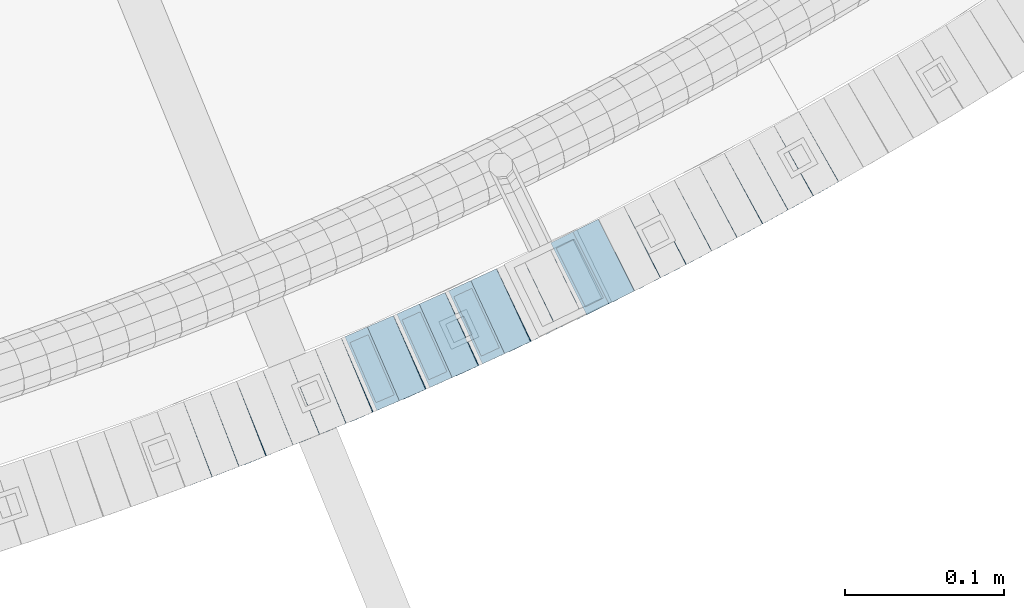
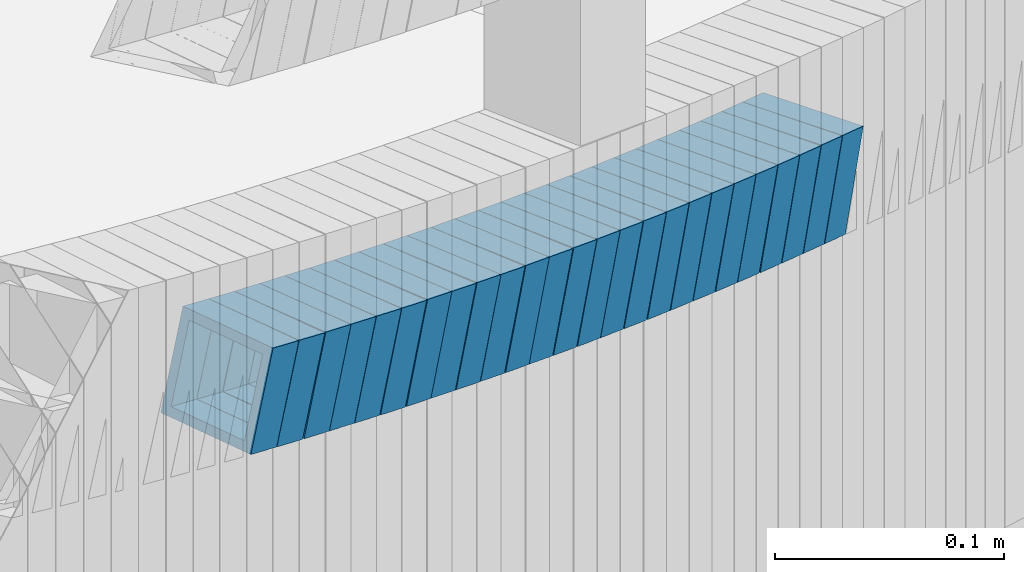
# One storey, part 763 of 975: 25 beams.
"""IFC2X3 building model written with IfcOpenShell, lengths in millimetres."""

from ifc_helpers import new_model, si_unit, frame, origin_with_axes, place, context, subcontext, project, spatial, faceted_brep, material, type_object, element, save


model = new_model("IFC2X3")

# Units and contexts
model_context = context("Model", 3, precision=1e-05, world=origin_with_axes())
body_context = subcontext(model_context, "Body", "Model", "MODEL_VIEW")
ifc_project = project(units=[si_unit("LENGTHUNIT", "METRE", prefix="MILLI"), si_unit("AREAUNIT", "SQUARE_METRE"), si_unit("VOLUMEUNIT", "CUBIC_METRE"), si_unit("MASSUNIT", "GRAM", prefix="KILO"), si_unit("TIMEUNIT", "SECOND"), si_unit("PLANEANGLEUNIT", "RADIAN"), si_unit("SOLIDANGLEUNIT", "STERADIAN"), si_unit("THERMODYNAMICTEMPERATUREUNIT", "DEGREE_CELSIUS"), si_unit("LUMINOUSINTENSITYUNIT", "LUMEN")], contexts=[model_context])

# Site, building, storey
site_placement = place(None, origin_with_axes())
site = spatial("IfcSite", under=ifc_project, at=site_placement, CompositionType="ELEMENT")
building_placement = place(site_placement, origin_with_axes())
building = spatial("IfcBuilding", under=site, at=building_placement, Name="Undefined", CompositionType="ELEMENT")
storey_placement = place(building_placement, origin_with_axes())
storey = spatial("IfcBuildingStorey", under=building, at=storey_placement, Name="Undefined", CompositionType="ELEMENT", Elevation=0.0)

# Beams
ifc_material = material()
beam_type = type_object("IfcBeamType", Name="HSS2X2X.188_TUBES", PredefinedType="NOTDEFINED")
beam_1_placement = place(storey_placement, frame((35750.552446329, 718.695826427397, 2958.19941195074), z_axis=(-0.357854758021058, 0.933777260465091, -4.67780409962871e-11), x_axis=(0.889683418026638, 0.340956519010209, -0.303664400009089)))
element("IfcBeam", 1, at=beam_1_placement, inside=storey, type_object=beam_type, material=ifc_material, Name="WALL", ObjectType="HSS2X2X.188_TUBES", context=body_context, shape_type="Brep", body=[
    faceted_brep([(0.0, 20.6374999999753, -20.6375000000298), (0.0, -20.6375000000153, -20.6375000000153), (18.767258723612, -20.6375000000025, -20.6374999999862), (18.7672587236229, 20.6374999999953, -20.637499999968), (0.0, -20.6374999999825, 20.6375000000335), (18.767258723612, -20.6375000000135, 20.6375000000153), (0.0, 20.6375000000116, 20.6375000000189), (18.7672587236266, 20.6374999999844, 20.6375000000371), (0.0, 25.3999999999724, -25.4000000000342), (0.0, 25.400000000016, 25.4000000000196), (18.7672587236302, 25.3999999999814, 25.4000000000342), (18.7672587236229, 25.399999999996, -25.3999999999687), (0.0, -25.399999999976, 25.4000000000378), (18.7672587236157, -25.4000000000142, 25.400000000016), (0.0, -25.400000000016, -25.4000000000196), (18.767258723612, -25.4000000000015, -25.3999999999905)], [[[0, 1, 2, 3]], [[1, 4, 5, 2]], [[4, 6, 7, 5]], [[6, 0, 3, 7]], [[8, 9, 10, 11]], [[9, 12, 13, 10]], [[12, 14, 15, 13]], [[14, 8, 11, 15]], [[13, 15, 11, 10], [5, 7, 3, 2]], [[14, 12, 9, 8], [6, 4, 1, 0]]]),
])
beam_2_placement = place(storey_placement, frame((35767.2894822871, 725.066744083415, 2952.53419018205), z_axis=(-0.362715533424744, 0.931899909760916, -1.4543775250786e-10), x_axis=(0.886618739868702, 0.345091125948895, -0.307927466954411)))
element("IfcBeam", 2, at=beam_2_placement, inside=storey, type_object=beam_type, material=ifc_material, Name="WALL", ObjectType="HSS2X2X.188_TUBES", context=body_context, shape_type="Brep", body=[
    faceted_brep([(0.0, 20.6374999999753, -20.6375000000298), (0.0, -20.6375000000153, -20.6375000000153), (18.8433011969464, -20.6374999999898, -20.6375000000226), (18.8433011969719, 20.6375000000007, -20.6374999999862), (0.0, -20.6374999999825, 20.6375000000335), (18.8433011969828, -20.6375000000044, 20.6375000000189), (0.0, 20.6375000000116, 20.6375000000189), (18.8433011970155, 20.6374999999862, 20.6375000000517), (0.0, 25.3999999999724, -25.4000000000342), (0.0, 25.400000000016, 25.4000000000196), (18.8433011970228, 25.3999999999833, 25.4000000000597), (18.8433011969719, 25.4000000000015, -25.3999999999869), (0.0, -25.399999999976, 25.4000000000378), (18.8433011969864, -25.4000000000051, 25.4000000000196), (0.0, -25.400000000016, -25.4000000000196), (18.8433011969391, -25.3999999999869, -25.4000000000269)], [[[0, 1, 2, 3]], [[1, 4, 5, 2]], [[4, 6, 7, 5]], [[6, 0, 3, 7]], [[8, 9, 10, 11]], [[9, 12, 13, 10]], [[12, 14, 15, 13]], [[14, 8, 11, 15]], [[13, 15, 11, 10], [5, 7, 3, 2]], [[14, 12, 9, 8], [6, 4, 1, 0]]]),
])
beam_3_placement = place(storey_placement, frame((35784.4255197932, 731.635710494934, 2946.69732250594), z_axis=(-0.374278314232696, 0.927316420373937, 2.4144355847966e-11), x_axis=(0.883603947282854, 0.356635328114164, -0.303406175097117)))
element("IfcBeam", 3, at=beam_3_placement, inside=storey, type_object=beam_type, material=ifc_material, Name="WALL", ObjectType="HSS2X2X.188_TUBES", context=body_context, shape_type="Brep", body=[
    faceted_brep([(0.0, 20.6374999999753, -20.6375000000298), (0.0, -20.6375000000153, -20.6375000000153), (18.7853666454903, -20.6375000000535, -20.6375000000326), (18.785366645363, 20.6374999999862, -20.6375000000044), (0.0, -20.6374999999825, 20.6375000000335), (18.785366645352, -20.6375000000007, 20.6374999999989), (0.0, 20.6375000000116, 20.6375000000189), (18.7853666453102, 20.6375000000025, 20.6374999999753), (0.0, 25.3999999999724, -25.4000000000342), (0.0, 25.400000000016, 25.4000000000196), (18.7853666452065, 25.4000000000451, 25.4000000000351), (18.7853666453739, 25.3999999999833, -25.400000000006), (0.0, -25.399999999976, 25.4000000000378), (18.7853666497213, -25.399999993424, 25.3999999995158), (0.0, -25.400000000016, -25.4000000000196), (18.7853666455194, -25.4000000000633, -25.4000000000406)], [[[0, 1, 2, 3]], [[1, 4, 5, 2]], [[4, 6, 7, 5]], [[6, 0, 3, 7]], [[8, 9, 10, 11]], [[9, 12, 13, 10]], [[12, 14, 15, 13]], [[14, 8, 11, 15]], [[13, 15, 11, 10], [5, 7, 3, 2]], [[14, 12, 9, 8], [6, 4, 1, 0]]]),
])
beam_4_placement = place(storey_placement, frame((35801.0473600464, 738.327037311758, 2941.00894090825), z_axis=(-0.376226421874497, 0.92652775429747, -7.30401552573312e-11), x_axis=(0.88242864795769, 0.358319511982818, -0.304838987985393)))
element("IfcBeam", 4, at=beam_4_placement, inside=storey, type_object=beam_type, material=ifc_material, Name="WALL", ObjectType="HSS2X2X.188_TUBES", context=body_context, shape_type="Brep", body=[
    faceted_brep([(0.0, 20.6374999999753, -20.6375000000298), (0.0, -20.6375000000153, -20.6375000000153), (18.6959888745805, -20.6374999999771, -20.6375000000407), (18.6959888746751, 20.637499999988, -20.6374999999716), (0.0, -20.6374999999825, 20.6375000000335), (18.6959888746969, -20.6375000000135, 20.6375000000371), (0.0, 20.6375000000116, 20.6375000000189), (18.6959888747988, 20.6374999999498, 20.6375000001062), (0.0, 25.3999999999724, -25.4000000000342), (0.0, 25.400000000016, 25.4000000000196), (18.695988874817, 25.3999999999414, 25.4000000001215), (18.6959888746678, 25.3999999999887, -25.399999999976), (0.0, -25.399999999976, 25.4000000000378), (18.6959888747042, -25.4000000000124, 25.4000000000378), (0.0, -25.400000000016, -25.4000000000196), (18.695988874555, -25.3999999999687, -25.4000000000597)], [[[0, 1, 2, 3]], [[1, 4, 5, 2]], [[4, 6, 7, 5]], [[6, 0, 3, 7]], [[8, 9, 10, 11]], [[9, 12, 13, 10]], [[12, 14, 15, 13]], [[14, 8, 11, 15]], [[13, 15, 11, 10], [5, 7, 3, 2]], [[14, 12, 9, 8], [6, 4, 1, 0]]]),
])
for number, where, z_axis, x_axis, name in (
    (5, (35817.5849439628, 744.998677276993, 2935.343717297), (-0.381031615465093, 0.924562008745796, -1.29251020553056e-10), (0.879290601000781, 0.362374308000324, -0.309083969000288), "WALL"),
    (6, (35834.3488784214, 751.86469113724, 2929.49937706686), (-0.385806130206089, 0.922579877243918, 3.06058609567117e-11), (0.87901605281516, 0.367588530922704, -0.303660090936138), "WALL"),
):
    element("IfcBeam", number, at=place(storey_placement, frame(where, z_axis=z_axis, x_axis=x_axis)), inside=storey, type_object=beam_type, material=ifc_material, Name=name, ObjectType="HSS2X2X.188_TUBES", context=body_context, shape_type="Brep", body=[
        faceted_brep([(0.0, 20.6374999999753, -20.6375000000298), (0.0, -20.6375000000153, -20.6375000000153), (18.767258723612, -20.6375000000025, -20.6374999999862), (18.7672587236229, 20.6374999999953, -20.637499999968), (0.0, -20.6374999999825, 20.6375000000335), (18.767258723612, -20.6375000000135, 20.6375000000153), (0.0, 20.6375000000116, 20.6375000000189), (18.7672587236266, 20.6374999999844, 20.6375000000371), (0.0, 25.3999999999724, -25.4000000000342), (0.0, 25.400000000016, 25.4000000000196), (18.7672587236302, 25.3999999999814, 25.4000000000342), (18.7672587236229, 25.399999999996, -25.3999999999687), (0.0, -25.399999999976, 25.4000000000378), (18.7672587236157, -25.4000000000142, 25.400000000016), (0.0, -25.400000000016, -25.4000000000196), (18.767258723612, -25.4000000000015, -25.3999999999905)], [[[0, 1, 2, 3]], [[1, 4, 5, 2]], [[4, 6, 7, 5]], [[6, 0, 3, 7]], [[8, 9, 10, 11]], [[9, 12, 13, 10]], [[12, 14, 15, 13]], [[14, 8, 11, 15]], [[13, 15, 11, 10], [5, 7, 3, 2]], [[14, 12, 9, 8], [6, 4, 1, 0]]]),
    ])
for number, where, z_axis, x_axis, name in (
    (7, (35851.1734294605, 758.798118205636, 2923.80108876772), (-0.397293344182006, 0.917691668627692, 1.00451416074065e-10), (0.874296820163237, 0.378506550070674, -0.303871456056748), "WALL"),
    (8, (35867.5734294605, 765.898118205637, 2918.10108876772), (-0.397293344182006, 0.917691668627692, 1.00451416074065e-10), (0.874296820163237, 0.378506550070674, -0.303871456056748), "WALL"),
):
    element("IfcBeam", number, at=place(storey_placement, frame(where, z_axis=z_axis, x_axis=x_axis)), inside=storey, type_object=beam_type, material=ifc_material, Name=name, ObjectType="HSS2X2X.188_TUBES", context=body_context, shape_type="Brep", body=[
        faceted_brep([(0.0, 20.6374999999753, -20.6375000000298), (0.0, -20.6375000000153, -20.6375000000153), (18.7555325170906, -20.6374999999916, -20.6374999999971), (18.7555325171452, 20.637499999988, -20.6374999999571), (0.0, -20.6374999999825, 20.6375000000335), (18.7555325170615, -20.6374999999844, 20.6374999999716), (0.0, 20.6375000000116, 20.6375000000189), (18.7555325171015, 20.6374999999953, 20.637500000008), (0.0, 25.3999999999724, -25.4000000000342), (0.0, 25.400000000016, 25.4000000000196), (18.7555325171015, 25.399999999996, 25.4000000000051), (18.7555325171488, 25.3999999999851, -25.3999999999505), (0.0, -25.399999999976, 25.4000000000378), (18.755532517047, -25.3999999999814, 25.3999999999578), (0.0, -25.400000000016, -25.4000000000196), (18.7555325170979, -25.3999999999924, -25.3999999999978)], [[[0, 1, 2, 3]], [[1, 4, 5, 2]], [[4, 6, 7, 5]], [[6, 0, 3, 7]], [[8, 9, 10, 11]], [[9, 12, 13, 10]], [[12, 14, 15, 13]], [[14, 8, 11, 15]], [[13, 15, 11, 10], [5, 7, 3, 2]], [[14, 12, 9, 8], [6, 4, 1, 0]]]),
    ])
beam_5_placement = place(storey_placement, frame((35884.1870645612, 772.985899412526, 2912.44194460413), z_axis=(-0.408734346507772, 0.91265340298761, 1.52139364217874e-10), x_axis=(0.868028798112544, 0.388749094050399, -0.308869143040036)))
element("IfcBeam", 9, at=beam_5_placement, inside=storey, type_object=beam_type, material=ifc_material, Name="WALL", ObjectType="HSS2X2X.188_TUBES", context=body_context, shape_type="Brep", body=[
    faceted_brep([(0.0, 20.6374999999753, -20.6375000000298), (0.0, -20.6375000000153, -20.6375000000153), (18.7771137292038, -20.637500000008, -20.6374999999862), (18.777113729182, 20.6375000000062, -20.6375000000189), (0.0, -20.6374999999825, 20.6375000000335), (18.7771137291729, -20.6374999999916, 20.6374999999753), (0.0, 20.6375000000116, 20.6375000000189), (18.7771137291529, 20.6375000000207, 20.6374999999389), (0.0, 25.3999999999724, -25.4000000000342), (0.0, 25.400000000016, 25.4000000000196), (18.7771137291475, 25.4000000000251, 25.3999999999287), (18.7771137291857, 25.4000000000051, -25.4000000000196), (0.0, -25.399999999976, 25.4000000000378), (18.7771137291711, -25.3999999999905, 25.3999999999724), (0.0, -25.400000000016, -25.4000000000196), (18.7771137292129, -25.4000000000124, -25.3999999999724)], [[[0, 1, 2, 3]], [[1, 4, 5, 2]], [[4, 6, 7, 5]], [[6, 0, 3, 7]], [[8, 9, 10, 11]], [[9, 12, 13, 10]], [[12, 14, 15, 13]], [[14, 8, 11, 15]], [[13, 15, 11, 10], [5, 7, 3, 2]], [[14, 12, 9, 8], [6, 4, 1, 0]]]),
])
beam_6_placement = place(storey_placement, frame((35900.5990108203, 780.336034853709, 2906.6024546398), z_axis=(-0.408734346507772, 0.91265340298761, 1.52139364217874e-10), x_axis=(0.869447721729163, 0.389384561878709, -0.304040000905298)))
element("IfcBeam", 10, at=beam_6_placement, inside=storey, type_object=beam_type, material=ifc_material, Name="WALL", ObjectType="HSS2X2X.188_TUBES", context=body_context, shape_type="Brep", body=[
    faceted_brep([(0.0, 20.6374999999753, -20.6375000000298), (0.0, -20.6375000000153, -20.6375000000153), (18.7547327359644, -20.6374999999844, -20.6375000000553), (18.7547327359898, 20.6375000000171, -20.6375000000335), (0.0, -20.6374999999825, 20.6375000000335), (18.7547327360044, -20.6374999999953, 20.6374999999898), (0.0, 20.6375000000116, 20.6375000000189), (18.7547327360262, 20.6375000000062, 20.6375000000116), (0.0, 25.3999999999724, -25.4000000000342), (0.0, 25.400000000016, 25.4000000000196), (18.7547327360371, 25.4000000000033, 25.4000000000124), (18.7547327359898, 25.4000000000178, -25.4000000000342), (0.0, -25.399999999976, 25.4000000000378), (18.7547327360044, -25.399999999996, 25.3999999999869), (0.0, -25.400000000016, -25.4000000000196), (18.7547327359498, -25.3999999999814, -25.4000000000597)], [[[0, 1, 2, 3]], [[1, 4, 5, 2]], [[4, 6, 7, 5]], [[6, 0, 3, 7]], [[8, 9, 10, 11]], [[9, 12, 13, 10]], [[12, 14, 15, 13]], [[14, 8, 11, 15]], [[13, 15, 11, 10], [5, 7, 3, 2]], [[14, 12, 9, 8], [6, 4, 1, 0]]]),
])
for number, where, z_axis, x_axis, name in (
    (11, (35917.225457405, 787.678477927043, 2900.90347230502), (-0.420123568281132, 0.907466907041094, 7.59446265874431e-11), (0.864470399833456, 0.400217777922895, -0.304165510941404), "WALL"),
    (12, (35933.4254574049, 795.178477927043, 2895.20347230502), (-0.420123568281132, 0.907466907041094, 7.59446265874431e-11), (0.864470399833456, 0.400217777922895, -0.304165510941404), "WALL"),
):
    element("IfcBeam", number, at=place(storey_placement, frame(where, z_axis=z_axis, x_axis=x_axis)), inside=storey, type_object=beam_type, material=ifc_material, Name=name, ObjectType="HSS2X2X.188_TUBES", context=body_context, shape_type="Brep", body=[
        faceted_brep([(0.0, 20.6374999999753, -20.6375000000298), (0.0, -20.6375000000153, -20.6375000000153), (18.7416648140024, -20.6375000000153, -20.6374999999825), (18.7416648139188, 20.6375000000189, -20.6375000000298), (0.0, -20.6374999999825, 20.6375000000335), (18.7416648140097, -20.6375000000189, 20.6375000000226), (0.0, 20.6375000000116, 20.6375000000189), (18.741664813926, 20.6375000000153, 20.6374999999753), (0.0, 25.3999999999724, -25.4000000000342), (0.0, 25.400000000016, 25.4000000000196), (18.7416648139224, 25.4000000000196, 25.3999999999687), (18.7416648139042, 25.4000000000233, -25.4000000000378), (0.0, -25.399999999976, 25.4000000000378), (18.7416648140133, -25.4000000000215, 25.4000000000269), (0.0, -25.400000000016, -25.4000000000196), (18.7416648140133, -25.4000000000196, -25.399999999976)], [[[0, 1, 2, 3]], [[1, 4, 5, 2]], [[4, 6, 7, 5]], [[6, 0, 3, 7]], [[8, 9, 10, 11]], [[9, 12, 13, 10]], [[12, 14, 15, 13]], [[14, 8, 11, 15]], [[13, 15, 11, 10], [5, 7, 3, 2]], [[14, 12, 9, 8], [6, 4, 1, 0]]]),
    ])
beam_7_placement = place(storey_placement, frame((35949.8418856824, 802.672526740991, 2889.54368106898), z_axis=(-0.431455496862996, 0.902134221846564, -1.86537363333628e-11), x_axis=(0.857962283033027, 0.410329787015794, -0.309079580011895)))
element("IfcBeam", 13, at=beam_7_placement, inside=storey, type_object=beam_type, material=ifc_material, Name="WALL", ObjectType="HSS2X2X.188_TUBES", context=body_context, shape_type="Brep", body=[
    faceted_brep([(0.0, 20.6374999999753, -20.6375000000298), (0.0, -20.6375000000153, -20.6375000000153), (18.767258723612, -20.6375000000025, -20.6374999999862), (18.7672587236229, 20.6374999999953, -20.637499999968), (0.0, -20.6374999999825, 20.6375000000335), (18.767258723612, -20.6375000000135, 20.6375000000153), (0.0, 20.6375000000116, 20.6375000000189), (18.7672587236266, 20.6374999999844, 20.6375000000371), (0.0, 25.3999999999724, -25.4000000000342), (0.0, 25.400000000016, 25.4000000000196), (18.7672587236302, 25.3999999999814, 25.4000000000342), (18.7672587236229, 25.399999999996, -25.3999999999687), (0.0, -25.399999999976, 25.4000000000378), (18.7672587236157, -25.4000000000142, 25.400000000016), (0.0, -25.400000000016, -25.4000000000196), (18.767258723612, -25.4000000000015, -25.3999999999905)], [[[0, 1, 2, 3]], [[1, 4, 5, 2]], [[4, 6, 7, 5]], [[6, 0, 3, 7]], [[8, 9, 10, 11]], [[9, 12, 13, 10]], [[12, 14, 15, 13]], [[14, 8, 11, 15]], [[13, 15, 11, 10], [5, 7, 3, 2]], [[14, 12, 9, 8], [6, 4, 1, 0]]]),
])
beam_8_placement = place(storey_placement, frame((35966.2002191751, 810.453333717846, 2883.69871465884), z_axis=(-0.435999194636003, 0.899947055263118, -1.40920292324154e-10), x_axis=(0.857475412684117, 0.41542287084696, -0.303578251888163)))
element("IfcBeam", 14, at=beam_8_placement, inside=storey, type_object=beam_type, material=ifc_material, Name="WALL", ObjectType="HSS2X2X.188_TUBES", context=body_context, shape_type="Brep", body=[
    faceted_brep([(0.0, 20.6374999999753, -20.6375000000298), (0.0, -20.6375000000153, -20.6375000000153), (18.7771137292038, -20.637500000008, -20.6374999999862), (18.777113729182, 20.6375000000062, -20.6375000000189), (0.0, -20.6374999999825, 20.6375000000335), (18.7771137291729, -20.6374999999916, 20.6374999999753), (0.0, 20.6375000000116, 20.6375000000189), (18.7771137291529, 20.6375000000207, 20.6374999999389), (0.0, 25.3999999999724, -25.4000000000342), (0.0, 25.400000000016, 25.4000000000196), (18.7771137291475, 25.4000000000251, 25.3999999999287), (18.7771137291857, 25.4000000000051, -25.4000000000196), (0.0, -25.399999999976, 25.4000000000378), (18.7771137291711, -25.3999999999905, 25.3999999999724), (0.0, -25.400000000016, -25.4000000000196), (18.7771137292129, -25.4000000000124, -25.3999999999724)], [[[0, 1, 2, 3]], [[1, 4, 5, 2]], [[4, 6, 7, 5]], [[6, 0, 3, 7]], [[8, 9, 10, 11]], [[9, 12, 13, 10]], [[12, 14, 15, 13]], [[14, 8, 11, 15]], [[13, 15, 11, 10], [5, 7, 3, 2]], [[14, 12, 9, 8], [6, 4, 1, 0]]]),
])
beam_9_placement = place(storey_placement, frame((35982.3326600387, 818.248051740198, 2878.01000509659), z_axis=(-0.438202246944682, 0.898876404614467, -1.0214671419817e-10), x_axis=(0.856055734430933, 0.417327170210078, -0.304969855153529)))
element("IfcBeam", 15, at=beam_9_placement, inside=storey, type_object=beam_type, material=ifc_material, Name="WALL", ObjectType="HSS2X2X.188_TUBES", context=body_context, shape_type="Brep", body=[
    faceted_brep([(0.0, 20.6374999999753, -20.6375000000298), (0.0, -20.6375000000153, -20.6375000000153), (18.6895692834223, -20.637499999988, -20.6374999999862), (18.6895692834369, 20.6374999999953, -20.6374999999534), (0.0, -20.6374999999825, 20.6375000000335), (18.6895692833914, -20.637499999988, 20.6374999999789), (0.0, 20.6375000000116, 20.6375000000189), (18.6895692834078, 20.6374999999953, 20.637500000008), (0.0, 25.3999999999724, -25.4000000000342), (0.0, 25.400000000016, 25.4000000000196), (18.6895692834059, 25.3999999999924, 25.4000000000087), (18.6895692834423, 25.3999999999942, -25.3999999999432), (0.0, -25.399999999976, 25.4000000000378), (18.6895692833878, -25.3999999999869, 25.3999999999687), (0.0, -25.400000000016, -25.4000000000196), (18.6895692834241, -25.3999999999869, -25.3999999999833)], [[[0, 1, 2, 3]], [[1, 4, 5, 2]], [[4, 6, 7, 5]], [[6, 0, 3, 7]], [[8, 9, 10, 11]], [[9, 12, 13, 10]], [[12, 14, 15, 13]], [[14, 8, 11, 15]], [[13, 15, 11, 10], [5, 7, 3, 2]], [[14, 12, 9, 8], [6, 4, 1, 0]]]),
])
beam_10_placement = place(storey_placement, frame((35998.5175540393, 826.052028299014, 2872.3382706792), z_axis=(-0.447213595461908, 0.894427191018941, 1.31206434161868e-10), x_axis=(0.850823137641054, 0.425411568820527, -0.308423386869884)))
element("IfcBeam", 16, at=beam_10_placement, inside=storey, type_object=beam_type, material=ifc_material, Name="WALL", ObjectType="HSS2X2X.188_TUBES", context=body_context, shape_type="Brep", body=[
    faceted_brep([(0.0, 20.6374999999753, -20.6375000000298), (0.0, -20.6375000000153, -20.6375000000153), (18.8066477608099, -20.6374999999862, -20.6375000000116), (18.8066477608172, 20.6375000000062, -20.6374999999971), (0.0, -20.6374999999825, 20.6375000000335), (18.8066477608463, -20.6375000000062, 20.6375000000407), (0.0, 20.6375000000116, 20.6375000000189), (18.8066477608536, 20.6374999999844, 20.637500000048), (0.0, 25.3999999999724, -25.4000000000342), (0.0, 25.400000000016, 25.4000000000196), (18.8066477608591, 25.3999999999814, 25.400000000056), (18.8066477608154, 25.4000000000051, -25.4000000000015), (0.0, -25.399999999976, 25.4000000000378), (18.8066477608518, -25.4000000000087, 25.4000000000451), (0.0, -25.400000000016, -25.4000000000196), (18.8066477608081, -25.3999999999851, -25.4000000000196)], [[[0, 1, 2, 3]], [[1, 4, 5, 2]], [[4, 6, 7, 5]], [[6, 0, 3, 7]], [[8, 9, 10, 11]], [[9, 12, 13, 10]], [[12, 14, 15, 13]], [[14, 8, 11, 15]], [[13, 15, 11, 10], [5, 7, 3, 2]], [[14, 12, 9, 8], [6, 4, 1, 0]]]),
])
beam_11_placement = place(storey_placement, frame((36014.7732497027, 834.137327005865, 2866.49330349805), z_axis=(-0.451668961259791, 0.892185602570733, 1.35294158098986e-10), x_axis=(0.850270319361305, 0.430449349182909, -0.302908801128715)))
element("IfcBeam", 17, at=beam_11_placement, inside=storey, type_object=beam_type, material=ifc_material, Name="WALL", ObjectType="HSS2X2X.188_TUBES", context=body_context, shape_type="Brep", body=[
    faceted_brep([(0.0, 20.6374999999753, -20.6375000000298), (0.0, -20.6375000000153, -20.6375000000153), (18.8225928075335, -20.6374999999935, -20.6375000000298), (18.8225928075699, 20.6374999999898, -20.6374999999825), (0.0, -20.6374999999825, 20.6375000000335), (18.8225928075772, -20.637500000008, 20.6375000000226), (0.0, 20.6375000000116, 20.6375000000189), (18.8225928076135, 20.6374999999753, 20.6375000000698), (0.0, 25.3999999999724, -25.4000000000342), (0.0, 25.400000000016, 25.4000000000196), (18.8225928076281, 25.3999999999705, 25.4000000000815), (18.8225928075663, 25.3999999999905, -25.3999999999796), (0.0, -25.399999999976, 25.4000000000378), (18.8225928075808, -25.4000000000087, 25.4000000000233), (0.0, -25.400000000016, -25.4000000000196), (18.8225928075226, -25.3999999999905, -25.4000000000378)], [[[0, 1, 2, 3]], [[1, 4, 5, 2]], [[4, 6, 7, 5]], [[6, 0, 3, 7]], [[8, 9, 10, 11]], [[9, 12, 13, 10]], [[12, 14, 15, 13]], [[14, 8, 11, 15]], [[13, 15, 11, 10], [5, 7, 3, 2]], [[14, 12, 9, 8], [6, 4, 1, 0]]]),
])
beam_12_placement = place(storey_placement, frame((36030.9543396844, 842.264884948122, 2860.79871465884), z_axis=(-0.458358127885098, 0.888767588631397, 2.12935447052587e-11), x_axis=(0.846823544044339, 0.436726608022867, -0.303578252015895)))
element("IfcBeam", 18, at=beam_12_placement, inside=storey, type_object=beam_type, material=ifc_material, Name="WALL", ObjectType="HSS2X2X.188_TUBES", context=body_context, shape_type="Brep", body=[
    faceted_brep([(0.0, 20.6374999999753, -20.6375000000298), (0.0, -20.6375000000153, -20.6375000000153), (18.7771137292038, -20.637500000008, -20.6374999999862), (18.777113729182, 20.6375000000062, -20.6375000000189), (0.0, -20.6374999999825, 20.6375000000335), (18.7771137291729, -20.6374999999916, 20.6374999999753), (0.0, 20.6375000000116, 20.6375000000189), (18.7771137291529, 20.6375000000207, 20.6374999999389), (0.0, 25.3999999999724, -25.4000000000342), (0.0, 25.400000000016, 25.4000000000196), (18.7771137291475, 25.4000000000251, 25.3999999999287), (18.7771137291857, 25.4000000000051, -25.4000000000196), (0.0, -25.399999999976, 25.4000000000378), (18.7771137291711, -25.3999999999905, 25.3999999999724), (0.0, -25.400000000016, -25.4000000000196), (18.7771137292129, -25.4000000000124, -25.3999999999724)], [[[0, 1, 2, 3]], [[1, 4, 5, 2]], [[4, 6, 7, 5]], [[6, 0, 3, 7]], [[8, 9, 10, 11]], [[9, 12, 13, 10]], [[12, 14, 15, 13]], [[14, 8, 11, 15]], [[13, 15, 11, 10], [5, 7, 3, 2]], [[14, 12, 9, 8], [6, 4, 1, 0]]]),
])
beam_13_placement = place(storey_placement, frame((36046.9278669936, 850.436948838022, 2855.14357239759), z_axis=(-0.46505350491363, 0.885282574982445, -2.21971276914701e-11), x_axis=(0.841939544831311, 0.442284697911386, -0.309066414938083)))
element("IfcBeam", 19, at=beam_13_placement, inside=storey, type_object=beam_type, material=ifc_material, Name="WALL", ObjectType="HSS2X2X.188_TUBES", context=body_context, shape_type="Brep", body=[
    faceted_brep([(0.0, 20.6374999999753, -20.6375000000298), (0.0, -20.6375000000153, -20.6375000000153), (18.767258723612, -20.6375000000025, -20.6374999999862), (18.7672587236229, 20.6374999999953, -20.637499999968), (0.0, -20.6374999999825, 20.6375000000335), (18.767258723612, -20.6375000000135, 20.6375000000153), (0.0, 20.6375000000116, 20.6375000000189), (18.7672587236266, 20.6374999999844, 20.6375000000371), (0.0, 25.3999999999724, -25.4000000000342), (0.0, 25.400000000016, 25.4000000000196), (18.7672587236302, 25.3999999999814, 25.4000000000342), (18.7672587236229, 25.399999999996, -25.3999999999687), (0.0, -25.399999999976, 25.4000000000378), (18.7672587236157, -25.4000000000142, 25.400000000016), (0.0, -25.400000000016, -25.4000000000196), (18.767258723612, -25.4000000000015, -25.3999999999905)], [[[0, 1, 2, 3]], [[1, 4, 5, 2]], [[4, 6, 7, 5]], [[6, 0, 3, 7]], [[8, 9, 10, 11]], [[9, 12, 13, 10]], [[12, 14, 15, 13]], [[14, 8, 11, 15]], [[13, 15, 11, 10], [5, 7, 3, 2]], [[14, 12, 9, 8], [6, 4, 1, 0]]]),
])
beam_14_placement = place(storey_placement, frame((36062.9816494338, 858.827533515692, 2849.29819222206), z_axis=(-0.469427601862633, 0.882970965892706, -2.25941221287939e-11), x_axis=(0.841318645365587, 0.447283330194367, -0.303513689131893)))
element("IfcBeam", 20, at=beam_14_placement, inside=storey, type_object=beam_type, material=ifc_material, Name="WALL", ObjectType="HSS2X2X.188_TUBES", context=body_context, shape_type="Brep", body=[
    faceted_brep([(0.0, 20.6374999999753, -20.6375000000298), (0.0, -20.6375000000153, -20.6375000000153), (18.7771137292038, -20.637500000008, -20.6374999999862), (18.777113729182, 20.6375000000062, -20.6375000000189), (0.0, -20.6374999999825, 20.6375000000335), (18.7771137291729, -20.6374999999916, 20.6374999999753), (0.0, 20.6375000000116, 20.6375000000189), (18.7771137291529, 20.6375000000207, 20.6374999999389), (0.0, 25.3999999999724, -25.4000000000342), (0.0, 25.400000000016, 25.4000000000196), (18.7771137291475, 25.4000000000251, 25.3999999999287), (18.7771137291857, 25.4000000000051, -25.4000000000196), (0.0, -25.399999999976, 25.4000000000378), (18.7771137291711, -25.3999999999905, 25.3999999999724), (0.0, -25.400000000016, -25.4000000000196), (18.7771137292129, -25.4000000000124, -25.3999999999724)], [[[0, 1, 2, 3]], [[1, 4, 5, 2]], [[4, 6, 7, 5]], [[6, 0, 3, 7]], [[8, 9, 10, 11]], [[9, 12, 13, 10]], [[12, 14, 15, 13]], [[14, 8, 11, 15]], [[13, 15, 11, 10], [5, 7, 3, 2]], [[14, 12, 9, 8], [6, 4, 1, 0]]]),
])
beam_15_placement = place(storey_placement, frame((36078.8183126701, 867.203825573369, 2843.6315202884), z_axis=(-0.473767410843312, 0.880650010175906, -7.15508576831779e-11), x_axis=(0.837951650145135, 0.450796774078082, -0.307602504053268)))
element("IfcBeam", 21, at=beam_15_placement, inside=storey, type_object=beam_type, material=ifc_material, Name="WALL", ObjectType="HSS2X2X.188_TUBES", context=body_context, shape_type="Brep", body=[
    faceted_brep([(0.0, 20.6374999999753, -20.6375000000298), (0.0, -20.6375000000153, -20.6375000000153), (18.8565638439322, -20.6375000000116, -20.6374999999643), (18.8565638439395, 20.637499999988, -20.6374999999534), (0.0, -20.6374999999825, 20.6375000000335), (18.856563843914, -20.6374999999953, 20.6375000000116), (0.0, 20.6375000000116, 20.6375000000189), (18.8565638439177, 20.6375000000007, 20.6375000000226), (0.0, 25.3999999999724, -25.4000000000342), (0.0, 25.400000000016, 25.4000000000196), (18.8565638439177, 25.4000000000033, 25.4000000000233), (18.8565638439468, 25.3999999999851, -25.3999999999505), (0.0, -25.399999999976, 25.4000000000378), (18.8565638439104, -25.399999999996, 25.4000000000087), (0.0, -25.400000000016, -25.4000000000196), (18.8565638439395, -25.4000000000124, -25.3999999999614)], [[[0, 1, 2, 3]], [[1, 4, 5, 2]], [[4, 6, 7, 5]], [[6, 0, 3, 7]], [[8, 9, 10, 11]], [[9, 12, 13, 10]], [[12, 14, 15, 13]], [[14, 8, 11, 15]], [[13, 15, 11, 10], [5, 7, 3, 2]], [[14, 12, 9, 8], [6, 4, 1, 0]]]),
])
beam_16_placement = place(storey_placement, frame((36094.9088952205, 875.794766646482, 2837.79732250594), z_axis=(-0.480416941000541, 0.877040228723679, 4.24188328906893e-11), x_axis=(0.835697709022857, 0.457770720012526, -0.303406175008291)))
element("IfcBeam", 22, at=beam_16_placement, inside=storey, type_object=beam_type, material=ifc_material, Name="WALL", ObjectType="HSS2X2X.188_TUBES", context=body_context, shape_type="Brep", body=[
    faceted_brep([(0.0, 20.6374999999753, -20.6375000000298), (0.0, -20.6375000000153, -20.6375000000153), (18.7853666454903, -20.6375000000535, -20.6375000000326), (18.785366645363, 20.6374999999862, -20.6375000000044), (0.0, -20.6374999999825, 20.6375000000335), (18.785366645352, -20.6375000000007, 20.6374999999989), (0.0, 20.6375000000116, 20.6375000000189), (18.7853666453102, 20.6375000000025, 20.6374999999753), (0.0, 25.3999999999724, -25.4000000000342), (0.0, 25.400000000016, 25.4000000000196), (18.7853666452065, 25.4000000000451, 25.4000000000351), (18.7853666453739, 25.3999999999833, -25.400000000006), (0.0, -25.399999999976, 25.4000000000378), (18.7853666497213, -25.399999993424, 25.3999999995158), (0.0, -25.400000000016, -25.4000000000196), (18.7853666455194, -25.4000000000633, -25.4000000000406)], [[[0, 1, 2, 3]], [[1, 4, 5, 2]], [[4, 6, 7, 5]], [[6, 0, 3, 7]], [[8, 9, 10, 11]], [[9, 12, 13, 10]], [[12, 14, 15, 13]], [[14, 8, 11, 15]], [[13, 15, 11, 10], [5, 7, 3, 2]], [[14, 12, 9, 8], [6, 4, 1, 0]]]),
])
for number, where, z_axis, x_axis, name in (
    (23, (36110.7522293607, 884.430796711464, 2832.09133851653), (-0.484696589219763, 0.874682351713311, -3.26514509652043e-10), (0.833657045858349, 0.461962820921509, -0.302665296948581), "WALL"),
    (24, (36126.5292876974, 893.106435219055, 2826.43540435357), (-0.491321187370494, 0.870978467495522, 1.84759755939013e-10), (0.828615846122445, 0.467424324069068, -0.308075122045516), "WALL"),
):
    element("IfcBeam", number, at=place(storey_placement, frame(where, z_axis=z_axis, x_axis=x_axis)), inside=storey, type_object=beam_type, material=ifc_material, Name=name, ObjectType="HSS2X2X.188_TUBES", context=body_context, shape_type="Brep", body=[
        faceted_brep([(0.0, 20.6374999999753, -20.6375000000298), (0.0, -20.6375000000153, -20.6375000000153), (18.8332159191086, -20.6374999999916, -20.6375000000153), (18.8332159190923, 20.6375000000062, -20.6375000000335), (0.0, -20.6374999999825, 20.6375000000335), (18.8332159191377, -20.6375000000062, 20.6375000000335), (0.0, 20.6375000000116, 20.6375000000189), (18.8332159191141, 20.6374999999916, 20.6375000000116), (0.0, 25.3999999999724, -25.4000000000342), (0.0, 25.400000000016, 25.4000000000196), (18.8332159191159, 25.3999999999905, 25.4000000000124), (18.8332159190886, 25.4000000000069, -25.4000000000415), (0.0, -25.399999999976, 25.4000000000378), (18.8332159191395, -25.4000000000069, 25.4000000000378), (0.0, -25.400000000016, -25.4000000000196), (18.8332159191104, -25.3999999999905, -25.400000000016)], [[[0, 1, 2, 3]], [[1, 4, 5, 2]], [[4, 6, 7, 5]], [[6, 0, 3, 7]], [[8, 9, 10, 11]], [[9, 12, 13, 10]], [[12, 14, 15, 13]], [[14, 8, 11, 15]], [[13, 15, 11, 10], [5, 7, 3, 2]], [[14, 12, 9, 8], [6, 4, 1, 0]]]),
    ])
beam_17_placement = place(storey_placement, frame((36142.272057563, 901.943854288651, 2820.62910955611), z_axis=(-0.495539204572793, 0.868585572486306, -1.97653662326047e-10), x_axis=(0.826554595212212, 0.471559993121071, -0.3073087600789)))
element("IfcBeam", 25, at=beam_17_placement, inside=storey, type_object=beam_type, material=ifc_material, Name="WALL", ObjectType="HSS2X2X.188_TUBES", context=body_context, shape_type="Brep", body=[
    faceted_brep([(0.0, 20.6374999999753, -20.6375000000298), (0.0, -20.6375000000153, -20.6375000000153), (18.8653120832787, -20.6374999999989, -20.6374999999935), (18.8653120832823, 20.6374999999971, -20.6374999999935), (0.0, -20.6374999999825, 20.6375000000335), (18.8653120833151, -20.6375000000116, 20.6375000000298), (0.0, 20.6375000000116, 20.6375000000189), (18.8653120833151, 20.6374999999844, 20.6375000000298), (0.0, 25.3999999999724, -25.4000000000342), (0.0, 25.400000000016, 25.4000000000196), (18.8653120833187, 25.3999999999814, 25.4000000000378), (18.8653120832823, 25.3999999999942, -25.3999999999905), (0.0, -25.399999999976, 25.4000000000378), (18.8653120833187, -25.4000000000124, 25.4000000000342), (0.0, -25.400000000016, -25.4000000000196), (18.8653120832787, -25.3999999999978, -25.3999999999942)], [[[0, 1, 2, 3]], [[1, 4, 5, 2]], [[4, 6, 7, 5]], [[6, 0, 3, 7]], [[8, 9, 10, 11]], [[9, 12, 13, 10]], [[12, 14, 15, 13]], [[14, 8, 11, 15]], [[13, 15, 11, 10], [5, 7, 3, 2]], [[14, 12, 9, 8], [6, 4, 1, 0]]]),
])

save(model, "model.ifc")
